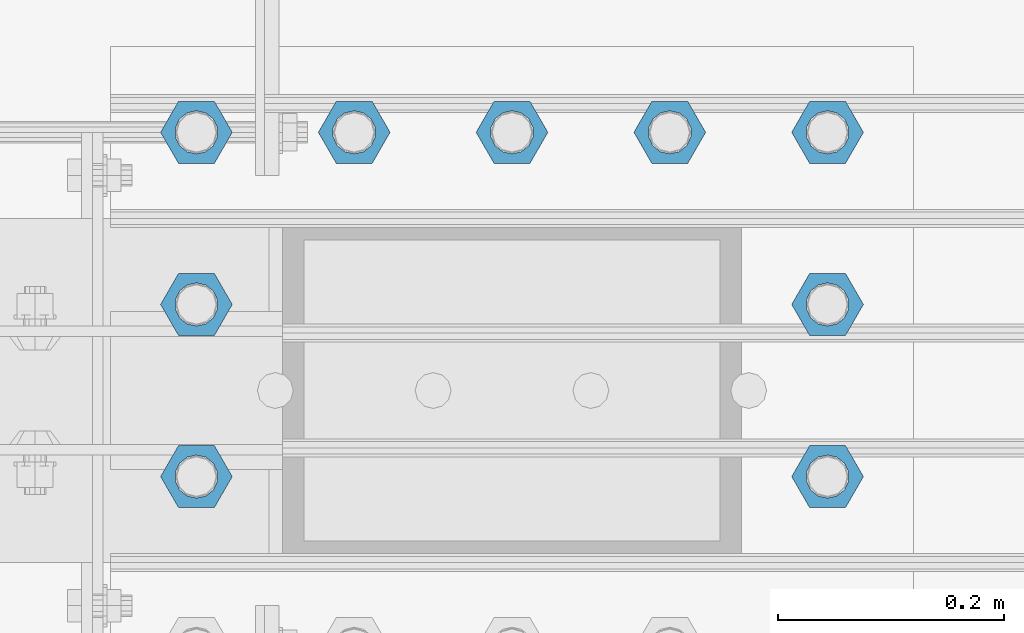
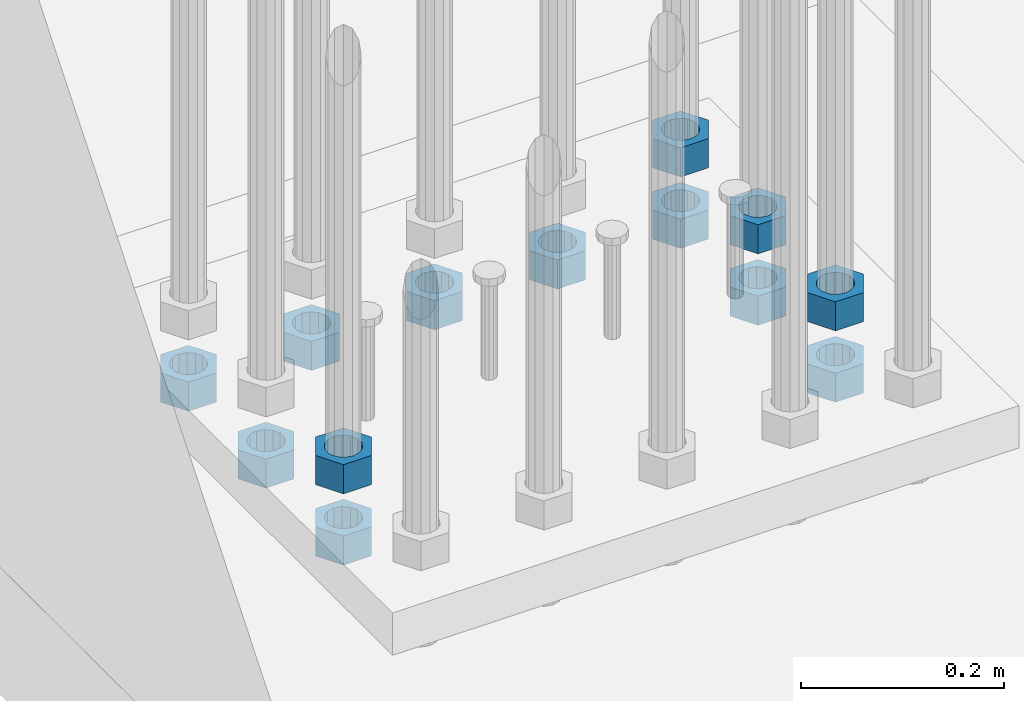
# One storey, part 1377 of 1876: 13 beams, 1 element without a shape of its own.
"""IFC2X3 building model written with IfcOpenShell, lengths in millimetres."""

from ifc_helpers import new_model, si_unit, frame, origin_with_axes, place, context, subcontext, project, spatial, faceted_brep, material, type_object, element, aggregate, save


model = new_model("IFC2X3")

# Units and contexts
model_context = context("Model", 3, precision=1e-05, world=origin_with_axes())
body_context = subcontext(model_context, "Body", "Model", "MODEL_VIEW")
ifc_project = project(units=[si_unit("LENGTHUNIT", "METRE", prefix="MILLI"), si_unit("AREAUNIT", "SQUARE_METRE"), si_unit("VOLUMEUNIT", "CUBIC_METRE"), si_unit("MASSUNIT", "GRAM", prefix="KILO"), si_unit("TIMEUNIT", "SECOND"), si_unit("PLANEANGLEUNIT", "RADIAN"), si_unit("SOLIDANGLEUNIT", "STERADIAN"), si_unit("THERMODYNAMICTEMPERATUREUNIT", "DEGREE_CELSIUS"), si_unit("LUMINOUSINTENSITYUNIT", "LUMEN")], contexts=[model_context])

# Site, building, storey
site_placement = place(None, origin_with_axes())
site = spatial("IfcSite", under=ifc_project, at=site_placement, CompositionType="ELEMENT")
building_placement = place(site_placement, origin_with_axes())
building = spatial("IfcBuilding", under=site, at=building_placement, Name="Undefined", CompositionType="ELEMENT")
storey_placement = place(building_placement, origin_with_axes())
storey = spatial("IfcBuildingStorey", under=building, at=storey_placement, Name="Undefined", CompositionType="ELEMENT", Elevation=0.0)

# Assembly, beams
assembly_placement = place(storey_placement, origin_with_axes())
assembly = element("IfcElementAssembly", 1, at=assembly_placement, inside=storey, Name="PLATE", AssemblyPlace="NOTDEFINED", PredefinedType="RIGID_FRAME")
ifc_material = material(Name="STEEL/A563")
beam_type = type_object("IfcBeamType", Name="1-3/8_HEAVY_HEX_NUT", PredefinedType="NOTDEFINED")
beam_1_placement = place(assembly_placement, frame((-47.6250091552728, -10845.799983724, -701.675000762939), z_axis=(0.0, -1.0, 0.0), x_axis=(0.0, 0.0, -1.0)))
beam_1 = element("IfcBeam", 2, at=beam_1_placement, type_object=beam_type, material=ifc_material, Name="NUT", ObjectType="1-3/8_HEAVY_HEX_NUT", context=body_context, shape_type="Brep", body=[
    faceted_brep([(0.0, -31.75, 0.0), (0.0, -15.8800001144409, -27.5), (34.925, -15.8800001144409, -27.5), (34.925, -31.75, 0.0), (0.0, 15.8800001144409, -27.5), (34.925, 15.8800001144409, -27.5), (0.0, 31.75, 0.0), (34.925, 31.75, 0.0), (0.0, 15.8800001144409, 27.5), (34.925, 15.8800001144409, 27.5), (0.0, -15.8800001144409, 27.5), (34.925, -15.8800001144409, 27.5), (0.0, 0.0, 19.0499999999993), (0.0, 8.2654848991624, 17.1634562461559), (34.925, 8.26548489916252, 17.163456246155), (34.925, 0.0, 19.0499992370605), (0.0, 14.8938891445259, 11.8774802497237), (34.925, 14.8938891445259, 11.8774802497246), (0.0, 18.5723759832526, 4.2390236220981), (34.925, 18.5723759832528, 4.23902362209628), (0.0, 18.5723759832526, -4.2390236220981), (34.925, 18.5723759832528, -4.23902362209628), (0.0, 14.8938891445259, -11.8774802497237), (34.925, 14.8938891445259, -11.8774802497246), (0.0, 8.2654848991624, -17.1634562461568), (34.925, 8.26548489916252, -17.163456246155), (0.0, 0.0, -19.05), (34.925, 0.0, -19.0499992370605), (0.0, -8.2654848991624, -17.1634562461559), (34.925, -8.26548489916252, -17.163456246155), (0.0, -14.8938891445259, -11.8774802497237), (34.925, -14.8938891445259, -11.8774802497246), (0.0, -18.5723759832526, -4.2390236220981), (34.925, -18.5723759832528, -4.23902362209628), (0.0, -18.5723759832526, 4.2390236220981), (34.925, -18.5723759832528, 4.23902362209628), (0.0, -14.8938891445259, 11.8774802497237), (34.925, -14.8938891445259, 11.8774802497246), (0.0, -8.2654848991624, 17.1634562461568), (34.925, -8.26548489916252, 17.163456246155)], [[[0, 1, 2, 3]], [[1, 4, 5, 2]], [[4, 6, 7, 5]], [[6, 8, 9, 7]], [[8, 10, 11, 9]], [[10, 0, 3, 11]], [[12, 13, 14, 15]], [[13, 16, 17, 14]], [[16, 18, 19, 17]], [[18, 20, 21, 19]], [[20, 22, 23, 21]], [[22, 24, 25, 23]], [[24, 26, 27, 25]], [[26, 28, 29, 27]], [[28, 30, 31, 29]], [[30, 32, 33, 31]], [[32, 34, 35, 33]], [[34, 36, 37, 35]], [[36, 38, 39, 37]], [[38, 12, 15, 39]], [[5, 7, 9, 11, 3, 2], [17, 19, 21, 23, 25, 27, 29, 31, 33, 35, 37, 39, 15, 14]], [[10, 8, 6, 4, 1, 0], [38, 36, 34, 32, 30, 28, 26, 24, 22, 20, 18, 16, 13, 12]]]),
])
beam_2_placement = place(assembly_placement, frame((511.175003051758, -10541.0, -701.675000762939), z_axis=(0.0, -1.0, 0.0), x_axis=(0.0, 0.0, -1.0)))
beam_2 = element("IfcBeam", 3, at=beam_2_placement, type_object=beam_type, material=ifc_material, Name="NUT", ObjectType="1-3/8_HEAVY_HEX_NUT", context=body_context, shape_type="Brep", body=[
    faceted_brep([(0.0, -31.75, 0.0), (0.0, -15.8800001144409, -27.5), (34.925, -15.8800001144409, -27.5), (34.925, -31.75, 0.0), (0.0, 15.8800001144409, -27.5), (34.925, 15.8800001144409, -27.5), (0.0, 31.75, 0.0), (34.925, 31.75, 0.0), (0.0, 15.8800001144409, 27.5), (34.925, 15.8800001144409, 27.5), (0.0, -15.8800001144409, 27.5), (34.925, -15.8800001144409, 27.5), (0.0, 0.0, 19.0499999999993), (0.0, 8.2654848991624, 17.1634562461559), (34.925, 8.26548489916252, 17.163456246155), (34.925, 0.0, 19.0499992370605), (0.0, 14.8938891445259, 11.8774802497237), (34.925, 14.8938891445259, 11.8774802497246), (0.0, 18.5723759832526, 4.2390236220981), (34.925, 18.5723759832528, 4.23902362209628), (0.0, 18.5723759832526, -4.2390236220981), (34.925, 18.5723759832528, -4.23902362209628), (0.0, 14.8938891445259, -11.8774802497237), (34.925, 14.8938891445259, -11.8774802497246), (0.0, 8.2654848991624, -17.1634562461568), (34.925, 8.26548489916252, -17.163456246155), (0.0, 0.0, -19.05), (34.925, 0.0, -19.0499992370605), (0.0, -8.2654848991624, -17.1634562461559), (34.925, -8.26548489916252, -17.163456246155), (0.0, -14.8938891445259, -11.8774802497237), (34.925, -14.8938891445259, -11.8774802497246), (0.0, -18.5723759832526, -4.2390236220981), (34.925, -18.5723759832528, -4.23902362209628), (0.0, -18.5723759832526, 4.2390236220981), (34.925, -18.5723759832528, 4.23902362209628), (0.0, -14.8938891445259, 11.8774802497237), (34.925, -14.8938891445259, 11.8774802497246), (0.0, -8.2654848991624, 17.1634562461568), (34.925, -8.26548489916252, 17.163456246155)], [[[0, 1, 2, 3]], [[1, 4, 5, 2]], [[4, 6, 7, 5]], [[6, 8, 9, 7]], [[8, 10, 11, 9]], [[10, 0, 3, 11]], [[12, 13, 14, 15]], [[13, 16, 17, 14]], [[16, 18, 19, 17]], [[18, 20, 21, 19]], [[20, 22, 23, 21]], [[22, 24, 25, 23]], [[24, 26, 27, 25]], [[26, 28, 29, 27]], [[28, 30, 31, 29]], [[30, 32, 33, 31]], [[32, 34, 35, 33]], [[34, 36, 37, 35]], [[36, 38, 39, 37]], [[38, 12, 15, 39]], [[5, 7, 9, 11, 3, 2], [17, 19, 21, 23, 25, 27, 29, 31, 33, 35, 37, 39, 15, 14]], [[10, 8, 6, 4, 1, 0], [38, 36, 34, 32, 30, 28, 26, 24, 22, 20, 18, 16, 13, 12]]]),
])
beam_3_placement = place(assembly_placement, frame((511.175003051758, -10693.399991862, -701.675000762939), z_axis=(0.0, -1.0, 0.0), x_axis=(0.0, 0.0, -1.0)))
beam_3 = element("IfcBeam", 4, at=beam_3_placement, type_object=beam_type, material=ifc_material, Name="NUT", ObjectType="1-3/8_HEAVY_HEX_NUT", context=body_context, shape_type="Brep", body=[
    faceted_brep([(0.0, -31.75, 0.0), (0.0, -15.8800001144409, -27.5), (34.925, -15.8800001144409, -27.5), (34.925, -31.75, 0.0), (0.0, 15.8800001144409, -27.5), (34.925, 15.8800001144409, -27.5), (0.0, 31.75, 0.0), (34.925, 31.75, 0.0), (0.0, 15.8800001144409, 27.5), (34.925, 15.8800001144409, 27.5), (0.0, -15.8800001144409, 27.5), (34.925, -15.8800001144409, 27.5), (0.0, 0.0, 19.0499999999993), (0.0, 8.2654848991624, 17.1634562461559), (34.925, 8.26548489916252, 17.163456246155), (34.925, 0.0, 19.0499992370605), (0.0, 14.8938891445259, 11.8774802497237), (34.925, 14.8938891445259, 11.8774802497246), (0.0, 18.5723759832526, 4.2390236220981), (34.925, 18.5723759832528, 4.23902362209628), (0.0, 18.5723759832526, -4.2390236220981), (34.925, 18.5723759832528, -4.23902362209628), (0.0, 14.8938891445259, -11.8774802497237), (34.925, 14.8938891445259, -11.8774802497246), (0.0, 8.2654848991624, -17.1634562461568), (34.925, 8.26548489916252, -17.163456246155), (0.0, 0.0, -19.05), (34.925, 0.0, -19.0499992370605), (0.0, -8.2654848991624, -17.1634562461559), (34.925, -8.26548489916252, -17.163456246155), (0.0, -14.8938891445259, -11.8774802497237), (34.925, -14.8938891445259, -11.8774802497246), (0.0, -18.5723759832526, -4.2390236220981), (34.925, -18.5723759832528, -4.23902362209628), (0.0, -18.5723759832526, 4.2390236220981), (34.925, -18.5723759832528, 4.23902362209628), (0.0, -14.8938891445259, 11.8774802497237), (34.925, -14.8938891445259, 11.8774802497246), (0.0, -8.2654848991624, 17.1634562461568), (34.925, -8.26548489916252, 17.163456246155)], [[[0, 1, 2, 3]], [[1, 4, 5, 2]], [[4, 6, 7, 5]], [[6, 8, 9, 7]], [[8, 10, 11, 9]], [[10, 0, 3, 11]], [[12, 13, 14, 15]], [[13, 16, 17, 14]], [[16, 18, 19, 17]], [[18, 20, 21, 19]], [[20, 22, 23, 21]], [[22, 24, 25, 23]], [[24, 26, 27, 25]], [[26, 28, 29, 27]], [[28, 30, 31, 29]], [[30, 32, 33, 31]], [[32, 34, 35, 33]], [[34, 36, 37, 35]], [[36, 38, 39, 37]], [[38, 12, 15, 39]], [[5, 7, 9, 11, 3, 2], [17, 19, 21, 23, 25, 27, 29, 31, 33, 35, 37, 39, 15, 14]], [[10, 8, 6, 4, 1, 0], [38, 36, 34, 32, 30, 28, 26, 24, 22, 20, 18, 16, 13, 12]]]),
])
beam_4_placement = place(assembly_placement, frame((511.175003051758, -10845.799983724, -701.675000762939), z_axis=(0.0, -1.0, 0.0), x_axis=(0.0, 0.0, -1.0)))
beam_4 = element("IfcBeam", 5, at=beam_4_placement, type_object=beam_type, material=ifc_material, Name="NUT", ObjectType="1-3/8_HEAVY_HEX_NUT", context=body_context, shape_type="Brep", body=[
    faceted_brep([(0.0, -31.75, 0.0), (0.0, -15.8800001144409, -27.5), (34.925, -15.8800001144409, -27.5), (34.925, -31.75, 0.0), (0.0, 15.8800001144409, -27.5), (34.925, 15.8800001144409, -27.5), (0.0, 31.75, 0.0), (34.925, 31.75, 0.0), (0.0, 15.8800001144409, 27.5), (34.925, 15.8800001144409, 27.5), (0.0, -15.8800001144409, 27.5), (34.925, -15.8800001144409, 27.5), (0.0, 0.0, 19.0499999999993), (0.0, 8.2654848991624, 17.1634562461559), (34.925, 8.26548489916252, 17.163456246155), (34.925, 0.0, 19.0499992370605), (0.0, 14.8938891445259, 11.8774802497237), (34.925, 14.8938891445259, 11.8774802497246), (0.0, 18.5723759832526, 4.2390236220981), (34.925, 18.5723759832528, 4.23902362209628), (0.0, 18.5723759832526, -4.2390236220981), (34.925, 18.5723759832528, -4.23902362209628), (0.0, 14.8938891445259, -11.8774802497237), (34.925, 14.8938891445259, -11.8774802497246), (0.0, 8.2654848991624, -17.1634562461568), (34.925, 8.26548489916252, -17.163456246155), (0.0, 0.0, -19.05), (34.925, 0.0, -19.0499992370605), (0.0, -8.2654848991624, -17.1634562461559), (34.925, -8.26548489916252, -17.163456246155), (0.0, -14.8938891445259, -11.8774802497237), (34.925, -14.8938891445259, -11.8774802497246), (0.0, -18.5723759832526, -4.2390236220981), (34.925, -18.5723759832528, -4.23902362209628), (0.0, -18.5723759832526, 4.2390236220981), (34.925, -18.5723759832528, 4.23902362209628), (0.0, -14.8938891445259, 11.8774802497237), (34.925, -14.8938891445259, 11.8774802497246), (0.0, -8.2654848991624, 17.1634562461568), (34.925, -8.26548489916252, 17.163456246155)], [[[0, 1, 2, 3]], [[1, 4, 5, 2]], [[4, 6, 7, 5]], [[6, 8, 9, 7]], [[8, 10, 11, 9]], [[10, 0, 3, 11]], [[12, 13, 14, 15]], [[13, 16, 17, 14]], [[16, 18, 19, 17]], [[18, 20, 21, 19]], [[20, 22, 23, 21]], [[22, 24, 25, 23]], [[24, 26, 27, 25]], [[26, 28, 29, 27]], [[28, 30, 31, 29]], [[30, 32, 33, 31]], [[32, 34, 35, 33]], [[34, 36, 37, 35]], [[36, 38, 39, 37]], [[38, 12, 15, 39]], [[5, 7, 9, 11, 3, 2], [17, 19, 21, 23, 25, 27, 29, 31, 33, 35, 37, 39, 15, 14]], [[10, 8, 6, 4, 1, 0], [38, 36, 34, 32, 30, 28, 26, 24, 22, 20, 18, 16, 13, 12]]]),
])
beam_5_placement = place(assembly_placement, frame((371.474987792969, -10541.0, -787.4), z_axis=(0.0, -1.0, 0.0), x_axis=(0.0, 0.0, -1.0)))
beam_5 = element("IfcBeam", 6, at=beam_5_placement, type_object=beam_type, material=ifc_material, Name="NUT", ObjectType="1-3/8_HEAVY_HEX_NUT", context=body_context, shape_type="Brep", body=[
    faceted_brep([(0.0, -31.75, 0.0), (0.0, -15.8800001144409, -27.5), (34.925, -15.8800001144409, -27.5), (34.925, -31.75, 0.0), (0.0, 15.8800001144409, -27.5), (34.925, 15.8800001144409, -27.5), (0.0, 31.75, 0.0), (34.925, 31.75, 0.0), (0.0, 15.8800001144409, 27.5), (34.925, 15.8800001144409, 27.5), (0.0, -15.8800001144409, 27.5), (34.925, -15.8800001144409, 27.5), (0.0, 0.0, 19.0499999999993), (0.0, 8.2654848991624, 17.1634562461559), (34.925, 8.26548489916252, 17.163456246155), (34.925, 0.0, 19.0499992370605), (0.0, 14.8938891445259, 11.8774802497237), (34.925, 14.8938891445259, 11.8774802497246), (0.0, 18.5723759832526, 4.2390236220981), (34.925, 18.5723759832528, 4.23902362209628), (0.0, 18.5723759832526, -4.2390236220981), (34.925, 18.5723759832528, -4.23902362209628), (0.0, 14.8938891445259, -11.8774802497237), (34.925, 14.8938891445259, -11.8774802497246), (0.0, 8.2654848991624, -17.1634562461568), (34.925, 8.26548489916252, -17.163456246155), (0.0, 0.0, -19.05), (34.925, 0.0, -19.0499992370605), (0.0, -8.2654848991624, -17.1634562461559), (34.925, -8.26548489916252, -17.163456246155), (0.0, -14.8938891445259, -11.8774802497237), (34.925, -14.8938891445259, -11.8774802497246), (0.0, -18.5723759832526, -4.2390236220981), (34.925, -18.5723759832528, -4.23902362209628), (0.0, -18.5723759832526, 4.2390236220981), (34.925, -18.5723759832528, 4.23902362209628), (0.0, -14.8938891445259, 11.8774802497237), (34.925, -14.8938891445259, 11.8774802497246), (0.0, -8.2654848991624, 17.1634562461568), (34.925, -8.26548489916252, 17.163456246155)], [[[0, 1, 2, 3]], [[1, 4, 5, 2]], [[4, 6, 7, 5]], [[6, 8, 9, 7]], [[8, 10, 11, 9]], [[10, 0, 3, 11]], [[12, 13, 14, 15]], [[13, 16, 17, 14]], [[16, 18, 19, 17]], [[18, 20, 21, 19]], [[20, 22, 23, 21]], [[22, 24, 25, 23]], [[24, 26, 27, 25]], [[26, 28, 29, 27]], [[28, 30, 31, 29]], [[30, 32, 33, 31]], [[32, 34, 35, 33]], [[34, 36, 37, 35]], [[36, 38, 39, 37]], [[38, 12, 15, 39]], [[5, 7, 9, 11, 3, 2], [17, 19, 21, 23, 25, 27, 29, 31, 33, 35, 37, 39, 15, 14]], [[10, 8, 6, 4, 1, 0], [38, 36, 34, 32, 30, 28, 26, 24, 22, 20, 18, 16, 13, 12]]]),
])
beam_6_placement = place(assembly_placement, frame((231.774987792969, -10541.0, -787.4), z_axis=(0.0, -1.0, 0.0), x_axis=(0.0, 0.0, -1.0)))
beam_6 = element("IfcBeam", 7, at=beam_6_placement, type_object=beam_type, material=ifc_material, Name="NUT", ObjectType="1-3/8_HEAVY_HEX_NUT", context=body_context, shape_type="Brep", body=[
    faceted_brep([(0.0, -31.75, 0.0), (0.0, -15.8800001144409, -27.5), (34.925, -15.8800001144409, -27.5), (34.925, -31.75, 0.0), (0.0, 15.8800001144409, -27.5), (34.925, 15.8800001144409, -27.5), (0.0, 31.75, 0.0), (34.925, 31.75, 0.0), (0.0, 15.8800001144409, 27.5), (34.925, 15.8800001144409, 27.5), (0.0, -15.8800001144409, 27.5), (34.925, -15.8800001144409, 27.5), (0.0, 0.0, 19.0499999999993), (0.0, 8.2654848991624, 17.1634562461559), (34.925, 8.26548489916252, 17.163456246155), (34.925, 0.0, 19.0499992370605), (0.0, 14.8938891445259, 11.8774802497237), (34.925, 14.8938891445259, 11.8774802497246), (0.0, 18.5723759832526, 4.2390236220981), (34.925, 18.5723759832528, 4.23902362209628), (0.0, 18.5723759832526, -4.2390236220981), (34.925, 18.5723759832528, -4.23902362209628), (0.0, 14.8938891445259, -11.8774802497237), (34.925, 14.8938891445259, -11.8774802497246), (0.0, 8.2654848991624, -17.1634562461568), (34.925, 8.26548489916252, -17.163456246155), (0.0, 0.0, -19.05), (34.925, 0.0, -19.0499992370605), (0.0, -8.2654848991624, -17.1634562461559), (34.925, -8.26548489916252, -17.163456246155), (0.0, -14.8938891445259, -11.8774802497237), (34.925, -14.8938891445259, -11.8774802497246), (0.0, -18.5723759832526, -4.2390236220981), (34.925, -18.5723759832528, -4.23902362209628), (0.0, -18.5723759832526, 4.2390236220981), (34.925, -18.5723759832528, 4.23902362209628), (0.0, -14.8938891445259, 11.8774802497237), (34.925, -14.8938891445259, 11.8774802497246), (0.0, -8.2654848991624, 17.1634562461568), (34.925, -8.26548489916252, 17.163456246155)], [[[0, 1, 2, 3]], [[1, 4, 5, 2]], [[4, 6, 7, 5]], [[6, 8, 9, 7]], [[8, 10, 11, 9]], [[10, 0, 3, 11]], [[12, 13, 14, 15]], [[13, 16, 17, 14]], [[16, 18, 19, 17]], [[18, 20, 21, 19]], [[20, 22, 23, 21]], [[22, 24, 25, 23]], [[24, 26, 27, 25]], [[26, 28, 29, 27]], [[28, 30, 31, 29]], [[30, 32, 33, 31]], [[32, 34, 35, 33]], [[34, 36, 37, 35]], [[36, 38, 39, 37]], [[38, 12, 15, 39]], [[5, 7, 9, 11, 3, 2], [17, 19, 21, 23, 25, 27, 29, 31, 33, 35, 37, 39, 15, 14]], [[10, 8, 6, 4, 1, 0], [38, 36, 34, 32, 30, 28, 26, 24, 22, 20, 18, 16, 13, 12]]]),
])
beam_7_placement = place(assembly_placement, frame((92.074987792969, -10541.0, -787.4), z_axis=(0.0, -1.0, 0.0), x_axis=(0.0, 0.0, -1.0)))
beam_7 = element("IfcBeam", 8, at=beam_7_placement, type_object=beam_type, material=ifc_material, Name="NUT", ObjectType="1-3/8_HEAVY_HEX_NUT", context=body_context, shape_type="Brep", body=[
    faceted_brep([(0.0, -31.75, 0.0), (0.0, -15.8800001144409, -27.5), (34.925, -15.8800001144409, -27.5), (34.925, -31.75, 0.0), (0.0, 15.8800001144409, -27.5), (34.925, 15.8800001144409, -27.5), (0.0, 31.75, 0.0), (34.925, 31.75, 0.0), (0.0, 15.8800001144409, 27.5), (34.925, 15.8800001144409, 27.5), (0.0, -15.8800001144409, 27.5), (34.925, -15.8800001144409, 27.5), (0.0, 0.0, 19.0499999999993), (0.0, 8.2654848991624, 17.1634562461559), (34.925, 8.26548489916252, 17.163456246155), (34.925, 0.0, 19.0499992370605), (0.0, 14.8938891445259, 11.8774802497237), (34.925, 14.8938891445259, 11.8774802497246), (0.0, 18.5723759832526, 4.2390236220981), (34.925, 18.5723759832528, 4.23902362209628), (0.0, 18.5723759832526, -4.2390236220981), (34.925, 18.5723759832528, -4.23902362209628), (0.0, 14.8938891445259, -11.8774802497237), (34.925, 14.8938891445259, -11.8774802497246), (0.0, 8.2654848991624, -17.1634562461568), (34.925, 8.26548489916252, -17.163456246155), (0.0, 0.0, -19.05), (34.925, 0.0, -19.0499992370605), (0.0, -8.2654848991624, -17.1634562461559), (34.925, -8.26548489916252, -17.163456246155), (0.0, -14.8938891445259, -11.8774802497237), (34.925, -14.8938891445259, -11.8774802497246), (0.0, -18.5723759832526, -4.2390236220981), (34.925, -18.5723759832528, -4.23902362209628), (0.0, -18.5723759832526, 4.2390236220981), (34.925, -18.5723759832528, 4.23902362209628), (0.0, -14.8938891445259, 11.8774802497237), (34.925, -14.8938891445259, 11.8774802497246), (0.0, -8.2654848991624, 17.1634562461568), (34.925, -8.26548489916252, 17.163456246155)], [[[0, 1, 2, 3]], [[1, 4, 5, 2]], [[4, 6, 7, 5]], [[6, 8, 9, 7]], [[8, 10, 11, 9]], [[10, 0, 3, 11]], [[12, 13, 14, 15]], [[13, 16, 17, 14]], [[16, 18, 19, 17]], [[18, 20, 21, 19]], [[20, 22, 23, 21]], [[22, 24, 25, 23]], [[24, 26, 27, 25]], [[26, 28, 29, 27]], [[28, 30, 31, 29]], [[30, 32, 33, 31]], [[32, 34, 35, 33]], [[34, 36, 37, 35]], [[36, 38, 39, 37]], [[38, 12, 15, 39]], [[5, 7, 9, 11, 3, 2], [17, 19, 21, 23, 25, 27, 29, 31, 33, 35, 37, 39, 15, 14]], [[10, 8, 6, 4, 1, 0], [38, 36, 34, 32, 30, 28, 26, 24, 22, 20, 18, 16, 13, 12]]]),
])
beam_8_placement = place(assembly_placement, frame((-47.625012207031, -10541.0, -787.4), z_axis=(0.0, -1.0, 0.0), x_axis=(0.0, 0.0, -1.0)))
beam_8 = element("IfcBeam", 9, at=beam_8_placement, type_object=beam_type, material=ifc_material, Name="NUT", ObjectType="1-3/8_HEAVY_HEX_NUT", context=body_context, shape_type="Brep", body=[
    faceted_brep([(0.0, -31.75, 0.0), (0.0, -15.8800001144409, -27.5), (34.925, -15.8800001144409, -27.5), (34.925, -31.75, 0.0), (0.0, 15.8800001144409, -27.5), (34.925, 15.8800001144409, -27.5), (0.0, 31.75, 0.0), (34.925, 31.75, 0.0), (0.0, 15.8800001144409, 27.5), (34.925, 15.8800001144409, 27.5), (0.0, -15.8800001144409, 27.5), (34.925, -15.8800001144409, 27.5), (0.0, 0.0, 19.0499999999993), (0.0, 8.2654848991624, 17.1634562461559), (34.925, 8.26548489916252, 17.163456246155), (34.925, 0.0, 19.0499992370605), (0.0, 14.8938891445259, 11.8774802497237), (34.925, 14.8938891445259, 11.8774802497246), (0.0, 18.5723759832526, 4.2390236220981), (34.925, 18.5723759832528, 4.23902362209628), (0.0, 18.5723759832526, -4.2390236220981), (34.925, 18.5723759832528, -4.23902362209628), (0.0, 14.8938891445259, -11.8774802497237), (34.925, 14.8938891445259, -11.8774802497246), (0.0, 8.2654848991624, -17.1634562461568), (34.925, 8.26548489916252, -17.163456246155), (0.0, 0.0, -19.05), (34.925, 0.0, -19.0499992370605), (0.0, -8.2654848991624, -17.1634562461559), (34.925, -8.26548489916252, -17.163456246155), (0.0, -14.8938891445259, -11.8774802497237), (34.925, -14.8938891445259, -11.8774802497246), (0.0, -18.5723759832526, -4.2390236220981), (34.925, -18.5723759832528, -4.23902362209628), (0.0, -18.5723759832526, 4.2390236220981), (34.925, -18.5723759832528, 4.23902362209628), (0.0, -14.8938891445259, 11.8774802497237), (34.925, -14.8938891445259, 11.8774802497246), (0.0, -8.2654848991624, 17.1634562461568), (34.925, -8.26548489916252, 17.163456246155)], [[[0, 1, 2, 3]], [[1, 4, 5, 2]], [[4, 6, 7, 5]], [[6, 8, 9, 7]], [[8, 10, 11, 9]], [[10, 0, 3, 11]], [[12, 13, 14, 15]], [[13, 16, 17, 14]], [[16, 18, 19, 17]], [[18, 20, 21, 19]], [[20, 22, 23, 21]], [[22, 24, 25, 23]], [[24, 26, 27, 25]], [[26, 28, 29, 27]], [[28, 30, 31, 29]], [[30, 32, 33, 31]], [[32, 34, 35, 33]], [[34, 36, 37, 35]], [[36, 38, 39, 37]], [[38, 12, 15, 39]], [[5, 7, 9, 11, 3, 2], [17, 19, 21, 23, 25, 27, 29, 31, 33, 35, 37, 39, 15, 14]], [[10, 8, 6, 4, 1, 0], [38, 36, 34, 32, 30, 28, 26, 24, 22, 20, 18, 16, 13, 12]]]),
])
beam_9_placement = place(assembly_placement, frame((-47.625012207031, -10693.399991862, -787.4), z_axis=(0.0, -1.0, 0.0), x_axis=(0.0, 0.0, -1.0)))
beam_9 = element("IfcBeam", 10, at=beam_9_placement, type_object=beam_type, material=ifc_material, Name="NUT", ObjectType="1-3/8_HEAVY_HEX_NUT", context=body_context, shape_type="Brep", body=[
    faceted_brep([(0.0, -31.75, 0.0), (0.0, -15.8800001144409, -27.5), (34.925, -15.8800001144409, -27.5), (34.925, -31.75, 0.0), (0.0, 15.8800001144409, -27.5), (34.925, 15.8800001144409, -27.5), (0.0, 31.75, 0.0), (34.925, 31.75, 0.0), (0.0, 15.8800001144409, 27.5), (34.925, 15.8800001144409, 27.5), (0.0, -15.8800001144409, 27.5), (34.925, -15.8800001144409, 27.5), (0.0, 0.0, 19.0499999999993), (0.0, 8.2654848991624, 17.1634562461559), (34.925, 8.26548489916252, 17.163456246155), (34.925, 0.0, 19.0499992370605), (0.0, 14.8938891445259, 11.8774802497237), (34.925, 14.8938891445259, 11.8774802497246), (0.0, 18.5723759832526, 4.2390236220981), (34.925, 18.5723759832528, 4.23902362209628), (0.0, 18.5723759832526, -4.2390236220981), (34.925, 18.5723759832528, -4.23902362209628), (0.0, 14.8938891445259, -11.8774802497237), (34.925, 14.8938891445259, -11.8774802497246), (0.0, 8.2654848991624, -17.1634562461568), (34.925, 8.26548489916252, -17.163456246155), (0.0, 0.0, -19.05), (34.925, 0.0, -19.0499992370605), (0.0, -8.2654848991624, -17.1634562461559), (34.925, -8.26548489916252, -17.163456246155), (0.0, -14.8938891445259, -11.8774802497237), (34.925, -14.8938891445259, -11.8774802497246), (0.0, -18.5723759832526, -4.2390236220981), (34.925, -18.5723759832528, -4.23902362209628), (0.0, -18.5723759832526, 4.2390236220981), (34.925, -18.5723759832528, 4.23902362209628), (0.0, -14.8938891445259, 11.8774802497237), (34.925, -14.8938891445259, 11.8774802497246), (0.0, -8.2654848991624, 17.1634562461568), (34.925, -8.26548489916252, 17.163456246155)], [[[0, 1, 2, 3]], [[1, 4, 5, 2]], [[4, 6, 7, 5]], [[6, 8, 9, 7]], [[8, 10, 11, 9]], [[10, 0, 3, 11]], [[12, 13, 14, 15]], [[13, 16, 17, 14]], [[16, 18, 19, 17]], [[18, 20, 21, 19]], [[20, 22, 23, 21]], [[22, 24, 25, 23]], [[24, 26, 27, 25]], [[26, 28, 29, 27]], [[28, 30, 31, 29]], [[30, 32, 33, 31]], [[32, 34, 35, 33]], [[34, 36, 37, 35]], [[36, 38, 39, 37]], [[38, 12, 15, 39]], [[5, 7, 9, 11, 3, 2], [17, 19, 21, 23, 25, 27, 29, 31, 33, 35, 37, 39, 15, 14]], [[10, 8, 6, 4, 1, 0], [38, 36, 34, 32, 30, 28, 26, 24, 22, 20, 18, 16, 13, 12]]]),
])
beam_10_placement = place(assembly_placement, frame((-47.625012207031, -10845.799983724, -787.4), z_axis=(0.0, -1.0, 0.0), x_axis=(0.0, 0.0, -1.0)))
beam_10 = element("IfcBeam", 11, at=beam_10_placement, type_object=beam_type, material=ifc_material, Name="NUT", ObjectType="1-3/8_HEAVY_HEX_NUT", context=body_context, shape_type="Brep", body=[
    faceted_brep([(0.0, -31.75, 0.0), (0.0, -15.8800001144409, -27.5), (34.925, -15.8800001144409, -27.5), (34.925, -31.75, 0.0), (0.0, 15.8800001144409, -27.5), (34.925, 15.8800001144409, -27.5), (0.0, 31.75, 0.0), (34.925, 31.75, 0.0), (0.0, 15.8800001144409, 27.5), (34.925, 15.8800001144409, 27.5), (0.0, -15.8800001144409, 27.5), (34.925, -15.8800001144409, 27.5), (0.0, 0.0, 19.0499999999993), (0.0, 8.2654848991624, 17.1634562461559), (34.925, 8.26548489916252, 17.163456246155), (34.925, 0.0, 19.0499992370605), (0.0, 14.8938891445259, 11.8774802497237), (34.925, 14.8938891445259, 11.8774802497246), (0.0, 18.5723759832526, 4.2390236220981), (34.925, 18.5723759832528, 4.23902362209628), (0.0, 18.5723759832526, -4.2390236220981), (34.925, 18.5723759832528, -4.23902362209628), (0.0, 14.8938891445259, -11.8774802497237), (34.925, 14.8938891445259, -11.8774802497246), (0.0, 8.2654848991624, -17.1634562461568), (34.925, 8.26548489916252, -17.163456246155), (0.0, 0.0, -19.05), (34.925, 0.0, -19.0499992370605), (0.0, -8.2654848991624, -17.1634562461559), (34.925, -8.26548489916252, -17.163456246155), (0.0, -14.8938891445259, -11.8774802497237), (34.925, -14.8938891445259, -11.8774802497246), (0.0, -18.5723759832526, -4.2390236220981), (34.925, -18.5723759832528, -4.23902362209628), (0.0, -18.5723759832526, 4.2390236220981), (34.925, -18.5723759832528, 4.23902362209628), (0.0, -14.8938891445259, 11.8774802497237), (34.925, -14.8938891445259, 11.8774802497246), (0.0, -8.2654848991624, 17.1634562461568), (34.925, -8.26548489916252, 17.163456246155)], [[[0, 1, 2, 3]], [[1, 4, 5, 2]], [[4, 6, 7, 5]], [[6, 8, 9, 7]], [[8, 10, 11, 9]], [[10, 0, 3, 11]], [[12, 13, 14, 15]], [[13, 16, 17, 14]], [[16, 18, 19, 17]], [[18, 20, 21, 19]], [[20, 22, 23, 21]], [[22, 24, 25, 23]], [[24, 26, 27, 25]], [[26, 28, 29, 27]], [[28, 30, 31, 29]], [[30, 32, 33, 31]], [[32, 34, 35, 33]], [[34, 36, 37, 35]], [[36, 38, 39, 37]], [[38, 12, 15, 39]], [[5, 7, 9, 11, 3, 2], [17, 19, 21, 23, 25, 27, 29, 31, 33, 35, 37, 39, 15, 14]], [[10, 8, 6, 4, 1, 0], [38, 36, 34, 32, 30, 28, 26, 24, 22, 20, 18, 16, 13, 12]]]),
])
beam_11_placement = place(assembly_placement, frame((511.175, -10541.0, -787.4), z_axis=(0.0, -1.0, 0.0), x_axis=(0.0, 0.0, -1.0)))
beam_11 = element("IfcBeam", 12, at=beam_11_placement, type_object=beam_type, material=ifc_material, Name="NUT", ObjectType="1-3/8_HEAVY_HEX_NUT", context=body_context, shape_type="Brep", body=[
    faceted_brep([(0.0, -31.75, 0.0), (0.0, -15.8800001144409, -27.5), (34.925, -15.8800001144409, -27.5), (34.925, -31.75, 0.0), (0.0, 15.8800001144409, -27.5), (34.925, 15.8800001144409, -27.5), (0.0, 31.75, 0.0), (34.925, 31.75, 0.0), (0.0, 15.8800001144409, 27.5), (34.925, 15.8800001144409, 27.5), (0.0, -15.8800001144409, 27.5), (34.925, -15.8800001144409, 27.5), (0.0, 0.0, 19.0499999999993), (0.0, 8.2654848991624, 17.1634562461559), (34.925, 8.26548489916252, 17.163456246155), (34.925, 0.0, 19.0499992370605), (0.0, 14.8938891445259, 11.8774802497237), (34.925, 14.8938891445259, 11.8774802497246), (0.0, 18.5723759832526, 4.2390236220981), (34.925, 18.5723759832528, 4.23902362209628), (0.0, 18.5723759832526, -4.2390236220981), (34.925, 18.5723759832528, -4.23902362209628), (0.0, 14.8938891445259, -11.8774802497237), (34.925, 14.8938891445259, -11.8774802497246), (0.0, 8.2654848991624, -17.1634562461568), (34.925, 8.26548489916252, -17.163456246155), (0.0, 0.0, -19.05), (34.925, 0.0, -19.0499992370605), (0.0, -8.2654848991624, -17.1634562461559), (34.925, -8.26548489916252, -17.163456246155), (0.0, -14.8938891445259, -11.8774802497237), (34.925, -14.8938891445259, -11.8774802497246), (0.0, -18.5723759832526, -4.2390236220981), (34.925, -18.5723759832528, -4.23902362209628), (0.0, -18.5723759832526, 4.2390236220981), (34.925, -18.5723759832528, 4.23902362209628), (0.0, -14.8938891445259, 11.8774802497237), (34.925, -14.8938891445259, 11.8774802497246), (0.0, -8.2654848991624, 17.1634562461568), (34.925, -8.26548489916252, 17.163456246155)], [[[0, 1, 2, 3]], [[1, 4, 5, 2]], [[4, 6, 7, 5]], [[6, 8, 9, 7]], [[8, 10, 11, 9]], [[10, 0, 3, 11]], [[12, 13, 14, 15]], [[13, 16, 17, 14]], [[16, 18, 19, 17]], [[18, 20, 21, 19]], [[20, 22, 23, 21]], [[22, 24, 25, 23]], [[24, 26, 27, 25]], [[26, 28, 29, 27]], [[28, 30, 31, 29]], [[30, 32, 33, 31]], [[32, 34, 35, 33]], [[34, 36, 37, 35]], [[36, 38, 39, 37]], [[38, 12, 15, 39]], [[5, 7, 9, 11, 3, 2], [17, 19, 21, 23, 25, 27, 29, 31, 33, 35, 37, 39, 15, 14]], [[10, 8, 6, 4, 1, 0], [38, 36, 34, 32, 30, 28, 26, 24, 22, 20, 18, 16, 13, 12]]]),
])
beam_12_placement = place(assembly_placement, frame((511.175, -10693.399991862, -787.4), z_axis=(0.0, -1.0, 0.0), x_axis=(0.0, 0.0, -1.0)))
beam_12 = element("IfcBeam", 13, at=beam_12_placement, type_object=beam_type, material=ifc_material, Name="NUT", ObjectType="1-3/8_HEAVY_HEX_NUT", context=body_context, shape_type="Brep", body=[
    faceted_brep([(0.0, -31.75, 0.0), (0.0, -15.8800001144409, -27.5), (34.925, -15.8800001144409, -27.5), (34.925, -31.75, 0.0), (0.0, 15.8800001144409, -27.5), (34.925, 15.8800001144409, -27.5), (0.0, 31.75, 0.0), (34.925, 31.75, 0.0), (0.0, 15.8800001144409, 27.5), (34.925, 15.8800001144409, 27.5), (0.0, -15.8800001144409, 27.5), (34.925, -15.8800001144409, 27.5), (0.0, 0.0, 19.0499999999993), (0.0, 8.2654848991624, 17.1634562461559), (34.925, 8.26548489916252, 17.163456246155), (34.925, 0.0, 19.0499992370605), (0.0, 14.8938891445259, 11.8774802497237), (34.925, 14.8938891445259, 11.8774802497246), (0.0, 18.5723759832526, 4.2390236220981), (34.925, 18.5723759832528, 4.23902362209628), (0.0, 18.5723759832526, -4.2390236220981), (34.925, 18.5723759832528, -4.23902362209628), (0.0, 14.8938891445259, -11.8774802497237), (34.925, 14.8938891445259, -11.8774802497246), (0.0, 8.2654848991624, -17.1634562461568), (34.925, 8.26548489916252, -17.163456246155), (0.0, 0.0, -19.05), (34.925, 0.0, -19.0499992370605), (0.0, -8.2654848991624, -17.1634562461559), (34.925, -8.26548489916252, -17.163456246155), (0.0, -14.8938891445259, -11.8774802497237), (34.925, -14.8938891445259, -11.8774802497246), (0.0, -18.5723759832526, -4.2390236220981), (34.925, -18.5723759832528, -4.23902362209628), (0.0, -18.5723759832526, 4.2390236220981), (34.925, -18.5723759832528, 4.23902362209628), (0.0, -14.8938891445259, 11.8774802497237), (34.925, -14.8938891445259, 11.8774802497246), (0.0, -8.2654848991624, 17.1634562461568), (34.925, -8.26548489916252, 17.163456246155)], [[[0, 1, 2, 3]], [[1, 4, 5, 2]], [[4, 6, 7, 5]], [[6, 8, 9, 7]], [[8, 10, 11, 9]], [[10, 0, 3, 11]], [[12, 13, 14, 15]], [[13, 16, 17, 14]], [[16, 18, 19, 17]], [[18, 20, 21, 19]], [[20, 22, 23, 21]], [[22, 24, 25, 23]], [[24, 26, 27, 25]], [[26, 28, 29, 27]], [[28, 30, 31, 29]], [[30, 32, 33, 31]], [[32, 34, 35, 33]], [[34, 36, 37, 35]], [[36, 38, 39, 37]], [[38, 12, 15, 39]], [[5, 7, 9, 11, 3, 2], [17, 19, 21, 23, 25, 27, 29, 31, 33, 35, 37, 39, 15, 14]], [[10, 8, 6, 4, 1, 0], [38, 36, 34, 32, 30, 28, 26, 24, 22, 20, 18, 16, 13, 12]]]),
])
beam_13_placement = place(assembly_placement, frame((511.175, -10845.799983724, -787.4), z_axis=(0.0, -1.0, 0.0), x_axis=(0.0, 0.0, -1.0)))
beam_13 = element("IfcBeam", 14, at=beam_13_placement, type_object=beam_type, material=ifc_material, Name="NUT", ObjectType="1-3/8_HEAVY_HEX_NUT", context=body_context, shape_type="Brep", body=[
    faceted_brep([(0.0, -31.75, 0.0), (0.0, -15.8800001144409, -27.5), (34.925, -15.8800001144409, -27.5), (34.925, -31.75, 0.0), (0.0, 15.8800001144409, -27.5), (34.925, 15.8800001144409, -27.5), (0.0, 31.75, 0.0), (34.925, 31.75, 0.0), (0.0, 15.8800001144409, 27.5), (34.925, 15.8800001144409, 27.5), (0.0, -15.8800001144409, 27.5), (34.925, -15.8800001144409, 27.5), (0.0, 0.0, 19.0499999999993), (0.0, 8.2654848991624, 17.1634562461559), (34.925, 8.26548489916252, 17.163456246155), (34.925, 0.0, 19.0499992370605), (0.0, 14.8938891445259, 11.8774802497237), (34.925, 14.8938891445259, 11.8774802497246), (0.0, 18.5723759832526, 4.2390236220981), (34.925, 18.5723759832528, 4.23902362209628), (0.0, 18.5723759832526, -4.2390236220981), (34.925, 18.5723759832528, -4.23902362209628), (0.0, 14.8938891445259, -11.8774802497237), (34.925, 14.8938891445259, -11.8774802497246), (0.0, 8.2654848991624, -17.1634562461568), (34.925, 8.26548489916252, -17.163456246155), (0.0, 0.0, -19.05), (34.925, 0.0, -19.0499992370605), (0.0, -8.2654848991624, -17.1634562461559), (34.925, -8.26548489916252, -17.163456246155), (0.0, -14.8938891445259, -11.8774802497237), (34.925, -14.8938891445259, -11.8774802497246), (0.0, -18.5723759832526, -4.2390236220981), (34.925, -18.5723759832528, -4.23902362209628), (0.0, -18.5723759832526, 4.2390236220981), (34.925, -18.5723759832528, 4.23902362209628), (0.0, -14.8938891445259, 11.8774802497237), (34.925, -14.8938891445259, 11.8774802497246), (0.0, -8.2654848991624, 17.1634562461568), (34.925, -8.26548489916252, 17.163456246155)], [[[0, 1, 2, 3]], [[1, 4, 5, 2]], [[4, 6, 7, 5]], [[6, 8, 9, 7]], [[8, 10, 11, 9]], [[10, 0, 3, 11]], [[12, 13, 14, 15]], [[13, 16, 17, 14]], [[16, 18, 19, 17]], [[18, 20, 21, 19]], [[20, 22, 23, 21]], [[22, 24, 25, 23]], [[24, 26, 27, 25]], [[26, 28, 29, 27]], [[28, 30, 31, 29]], [[30, 32, 33, 31]], [[32, 34, 35, 33]], [[34, 36, 37, 35]], [[36, 38, 39, 37]], [[38, 12, 15, 39]], [[5, 7, 9, 11, 3, 2], [17, 19, 21, 23, 25, 27, 29, 31, 33, 35, 37, 39, 15, 14]], [[10, 8, 6, 4, 1, 0], [38, 36, 34, 32, 30, 28, 26, 24, 22, 20, 18, 16, 13, 12]]]),
])
aggregate(assembly, [beam_1, beam_2, beam_3, beam_4, beam_5, beam_6, beam_7, beam_8, beam_9, beam_10, beam_11, beam_12, beam_13])

save(model, "model.ifc")
